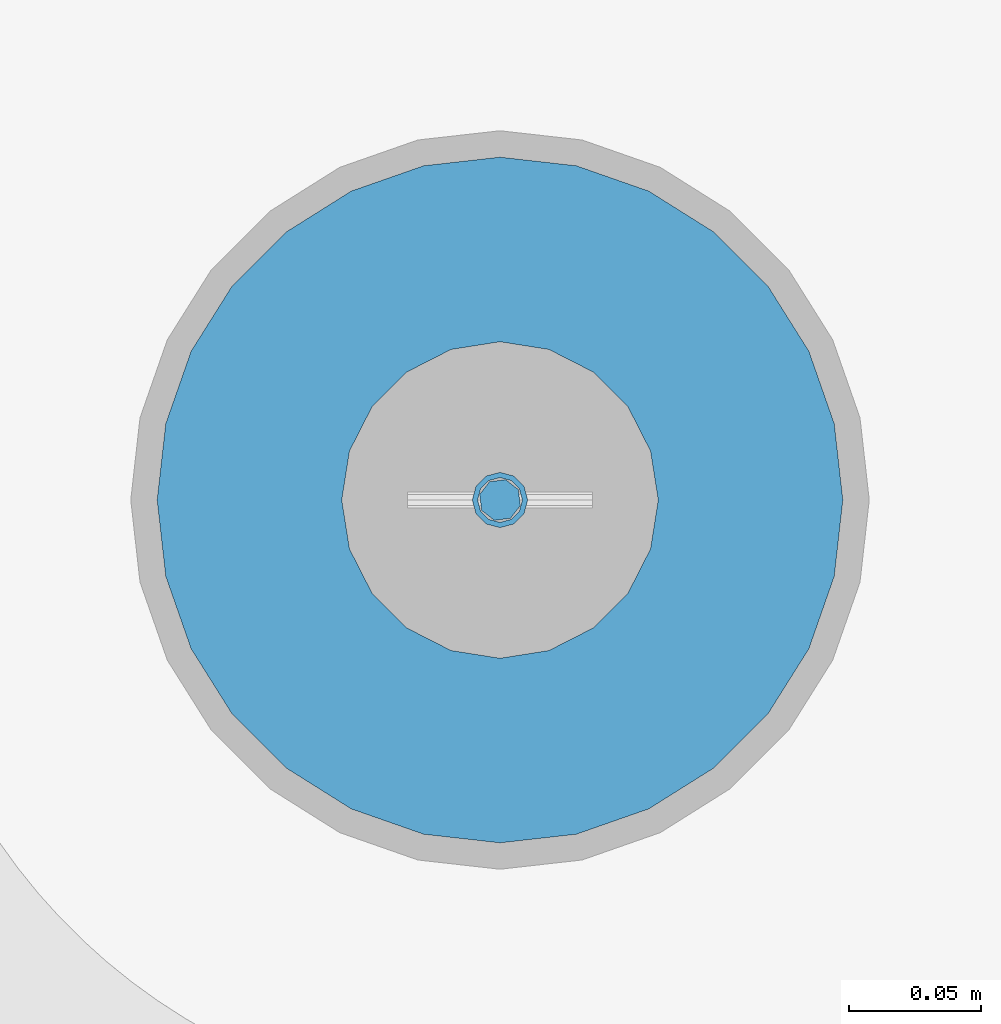
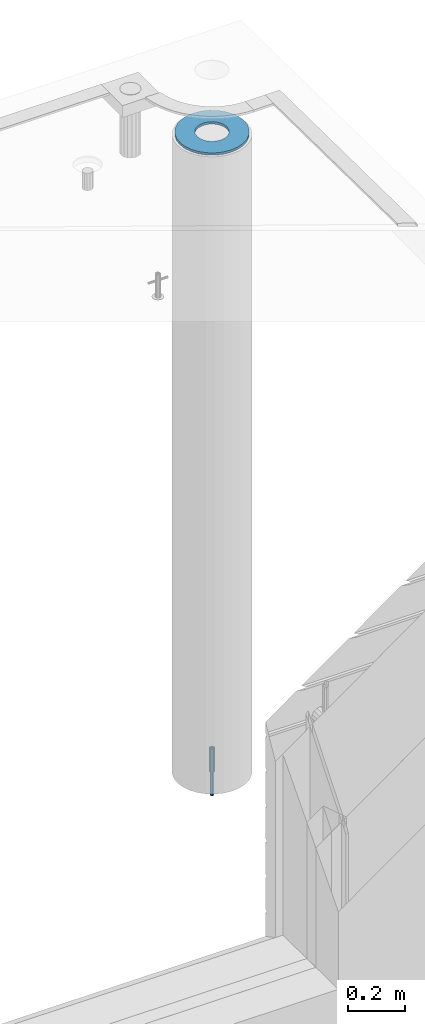
# One storey, part 33 of 325: 3 columns, 3 elements without a shape of their own.
"""IFC2X3 building model written with IfcOpenShell, lengths in millimetres."""

from ifc_helpers import new_model, si_unit, frame, origin_with_axes, place, context, subcontext, project, spatial, faceted_brep, material, type_object, element, aggregate, save


model = new_model("IFC2X3")

# Units and contexts
model_context = context("Model", 3, precision=1e-05, world=origin_with_axes())
body_context = subcontext(model_context, "Body", "Model", "MODEL_VIEW")
ifc_project = project(units=[si_unit("LENGTHUNIT", "METRE", prefix="MILLI"), si_unit("AREAUNIT", "SQUARE_METRE"), si_unit("VOLUMEUNIT", "CUBIC_METRE"), si_unit("MASSUNIT", "GRAM", prefix="KILO"), si_unit("TIMEUNIT", "SECOND"), si_unit("PLANEANGLEUNIT", "RADIAN"), si_unit("SOLIDANGLEUNIT", "STERADIAN"), si_unit("THERMODYNAMICTEMPERATUREUNIT", "DEGREE_CELSIUS"), si_unit("LUMINOUSINTENSITYUNIT", "LUMEN")], contexts=[model_context])

# Site, building, storey
site_placement = place(None, origin_with_axes())
site = spatial("IfcSite", under=ifc_project, at=site_placement, CompositionType="ELEMENT")
building_placement = place(site_placement, origin_with_axes())
building = spatial("IfcBuilding", under=site, at=building_placement, CompositionType="ELEMENT")
storey_placement = place(building_placement, origin_with_axes())
storey = spatial("IfcBuildingStorey", under=building, at=storey_placement, Name="1", CompositionType="ELEMENT", Elevation=0.0)

# Assemblies, columns
assembly_1_placement = place(storey_placement, origin_with_axes())
assembly_1 = element("IfcElementAssembly", 1, at=assembly_1_placement, inside=storey, AssemblyPlace="NOTDEFINED", PredefinedType="REINFORCEMENT_UNIT")
assembly_2_placement = place(assembly_1_placement, origin_with_axes())
assembly_2 = element("IfcElementAssembly", 2, at=assembly_2_placement, Name="Steel Assembly", AssemblyPlace="NOTDEFINED", PredefinedType="RIGID_FRAME")
ifc_material_1 = material(Name="STEEL/S235JR")
column_type_1 = type_object("IfcColumnType", Name="D16", PredefinedType="NOTDEFINED")
column_1_placement = place(assembly_2_placement, frame((35010.0004801435, 22669.9842012047, 81625.0), z_axis=(-0.261346946111888, -0.96524492941325, 0.0), x_axis=(0.0, 0.0, 1.0)))
column_1 = element("IfcColumn", 3, at=column_1_placement, type_object=column_type_1, material=ifc_material_1, Name="M16", ObjectType="D16", context=body_context, shape_type="Brep", body=[
    faceted_brep([(0.0, -8.0, 0.0), (0.0, -5.65685424949334, -5.65685424949334), (150.0, -5.65685424949697, -5.65685424949334), (150.0, -8.00000000000364, 0.0), (0.0, 0.0, -8.0), (150.0, -7.27595761418343e-12, -7.99999999999636), (0.0, 5.65685424949334, -5.65685424949334), (150.0, 5.6568542494897, -5.65685424949334), (0.0, 8.0, 0.0), (150.0, 8.0, -3.63797880709171e-12), (0.0, 5.65685424949334, 5.65685424949334), (150.0, 5.65685424949334, 5.65685424949697), (0.0, 0.0, 8.0), (150.0, -3.63797880709171e-12, 8.0), (0.0, -5.65685424949334, 5.65685424949334), (150.0, -5.65685424949334, 5.6568542494897)], [[[0, 1, 2, 3]], [[1, 4, 5, 2]], [[4, 6, 7, 5]], [[6, 8, 9, 7]], [[8, 10, 11, 9]], [[10, 12, 13, 11]], [[12, 14, 15, 13]], [[14, 0, 3, 15]], [[5, 7, 9, 11, 13, 15, 3, 2]], [[14, 12, 10, 8, 6, 4, 1, 0]]]),
])
aggregate(assembly_2, [column_1])
assembly_3_placement = place(assembly_1_placement, origin_with_axes())
assembly_3 = element("IfcElementAssembly", 4, at=assembly_3_placement, Name="Steel Assembly", AssemblyPlace="NOTDEFINED", PredefinedType="RIGID_FRAME")
ifc_material_2 = material(Name="STEEL/Steel_Undefined")
column_type_2 = type_object("IfcColumnType", PredefinedType="NOTDEFINED")
column_2_placement = place(assembly_3_placement, frame((35009.9987952044, 22669.984888838, 81725.0), z_axis=(0.0, 1.0, 0.0), x_axis=(0.0, 0.0, 1.0)))
column_2 = element("IfcColumn", 5, at=column_2_placement, type_object=column_type_2, material=ifc_material_2, context=body_context, shape_type="Brep", body=[
    faceted_brep([(0.0, -8.49999999999272, -1.45519152283669e-11), (0.0, -7.36121593215648, 4.24999999998545), (100.000000000262, -7.36121593215648, 4.24999999998545), (100.000000000262, -8.49999999999272, -1.45519152283669e-11), (0.0, -4.24999999998545, 7.36121593216376), (100.000000000262, -4.24999999998545, 7.36121593216376), (0.0, 1.45519152283669e-11, 8.49999999998545), (100.000000000262, 1.45519152283669e-11, 8.49999999998545), (0.0, 4.25000000001455, 7.36121593216376), (100.000000000262, 4.25000000001455, 7.36121593216376), (0.0, 7.36121593217104, 4.24999999998545), (100.000000000262, 7.36121593217104, 4.24999999998545), (0.0, 8.50000000000728, 0.0), (100.000000000262, 8.50000000000728, 0.0), (0.0, 7.36121593217104, -4.25000000001455), (100.000000000262, 7.36121593217104, -4.25000000001455), (0.0, 4.25000000000728, -7.36121593219286), (100.000000000262, 4.25000000000728, -7.36121593219286), (0.0, 7.27595761418343e-12, -8.5), (100.000000000262, 7.27595761418343e-12, -8.5), (0.0, -4.24999999999272, -7.36121593217831), (100.000000000262, -4.24999999999272, -7.36121593217831), (0.0, -7.36121593215648, -4.25), (100.000000000262, -7.36121593215648, -4.25), (0.0, -10.4999999999927, -1.45519152283669e-11), (0.0, -9.09326673972828, -5.25000000001455), (100.000000000262, -9.09326673972828, -5.25000000001455), (100.000000000262, -10.4999999999927, -1.45519152283669e-11), (0.0, -5.24999999998545, -9.09326673974283), (100.000000000262, -5.24999999998545, -9.09326673974283), (0.0, 7.27595761418343e-12, -10.5), (100.000000000262, 7.27595761418343e-12, -10.5), (0.0, 5.25000000001455, -9.09326673975738), (100.000000000262, 5.25000000001455, -9.09326673975738), (0.0, 9.09326673975011, -5.25000000001455), (100.000000000262, 9.09326673975011, -5.25000000001455), (0.0, 10.5000000000073, -1.45519152283669e-11), (100.000000000262, 10.5000000000073, -1.45519152283669e-11), (0.0, 9.09326673975011, 5.25), (100.000000000262, 9.09326673975011, 5.25), (0.0, 5.25000000000728, 9.09326673972828), (100.000000000262, 5.25000000000728, 9.09326673972828), (0.0, 1.45519152283669e-11, 10.4999999999854), (100.000000000262, 1.45519152283669e-11, 10.4999999999854), (0.0, -5.24999999999272, 9.09326673972828), (100.000000000262, -5.24999999999272, 9.09326673972828), (0.0, -9.09326673972828, 5.24999999998545), (100.000000000262, -9.09326673972828, 5.24999999998545)], [[[0, 1, 2, 3]], [[1, 4, 5, 2]], [[4, 6, 7, 5]], [[6, 8, 9, 7]], [[8, 10, 11, 9]], [[10, 12, 13, 11]], [[12, 14, 15, 13]], [[14, 16, 17, 15]], [[16, 18, 19, 17]], [[18, 20, 21, 19]], [[20, 22, 23, 21]], [[22, 0, 3, 23]], [[24, 25, 26, 27]], [[25, 28, 29, 26]], [[28, 30, 31, 29]], [[30, 32, 33, 31]], [[32, 34, 35, 33]], [[34, 36, 37, 35]], [[36, 38, 39, 37]], [[38, 40, 41, 39]], [[40, 42, 43, 41]], [[42, 44, 45, 43]], [[44, 46, 47, 45]], [[46, 24, 27, 47]], [[29, 31, 33, 35, 37, 39, 41, 43, 45, 47, 27, 26], [5, 7, 9, 11, 13, 15, 17, 19, 21, 23, 3, 2]], [[46, 44, 42, 40, 38, 36, 34, 32, 30, 28, 25, 24], [22, 20, 18, 16, 14, 12, 10, 8, 6, 4, 1, 0]]]),
])
aggregate(assembly_3, [column_2])
ifc_material_3 = material()
column_type_3 = type_object("IfcColumnType", Name="D260", PredefinedType="NOTDEFINED")
column_3_placement = place(assembly_1_placement, frame((35009.9987952044, 22669.984888838, 84435.0), z_axis=(-1.0, 3.00000001838171e-08, 0.0), x_axis=(0.0, 0.0, 1.0)))
column_3 = element("IfcColumn", 6, at=column_3_placement, type_object=column_type_3, material=ifc_material_3, Name="60", ObjectType="D260", context=body_context, shape_type="Brep", body=[
    faceted_brep([(10.0, -18.541019662498, -57.0633909777098), (0.0, -18.541019662498, -57.0633909777098), (0.0, -35.2671151375471, -48.5410196624944), (10.0, -35.2671151375471, -48.5410196624944), (0.0, -48.541019662498, -35.2671151375471), (10.0, -48.541019662498, -35.2671151375471), (0.0, -57.0633909777098, -18.5410196624944), (10.0, -57.0633909777098, -18.5410196624944), (0.0, -60.0, 0.0), (10.0, -60.0, 0.0), (0.0, -57.0633909777098, 18.5410196624944), (10.0, -57.0633909777098, 18.5410196624944), (0.0, -48.541019662498, 35.2671151375471), (10.0, -48.541019662498, 35.2671151375471), (0.0, -35.2671151375471, 48.5410196624944), (10.0, -35.2671151375471, 48.5410196624944), (0.0, -18.541019662498, 57.0633909777098), (10.0, -18.541019662498, 57.0633909777098), (0.0, 0.0, 60.0), (10.0, 0.0, 60.0), (0.0, 18.541019662498, 57.0633909777098), (10.0, 18.541019662498, 57.0633909777098), (0.0, 35.2671151375471, 48.5410196624944), (10.0, 35.2671151375471, 48.5410196624944), (0.0, 48.541019662498, 35.2671151375471), (10.0, 48.541019662498, 35.2671151375471), (0.0, 57.0633909777098, 18.5410196624944), (10.0, 57.0633909777098, 18.5410196624944), (0.0, 60.0, 0.0), (10.0, 60.0, 0.0), (0.0, 57.0633909777098, -18.5410196624944), (10.0, 57.0633909777098, -18.5410196624944), (0.0, 48.541019662498, -35.2671151375471), (10.0, 48.541019662498, -35.2671151375471), (0.0, 35.2671151375471, -48.5410196624944), (10.0, 35.2671151375471, -48.5410196624944), (0.0, 18.541019662498, -57.0633909777098), (10.0, 18.541019662498, -57.0633909777098), (0.0, 0.0, -60.0), (10.0, 0.0, -60.0), (0.0, -126.740628583637, -28.9277214143222), (0.0, -117.125952827315, -56.4048860852854), (10.0, -117.125952827315, -56.4048860852854), (10.0, -126.740628583637, -28.9277214143222), (0.0, -101.638092720845, -81.0536742416371), (10.0, -101.638092720845, -81.0536742416371), (0.0, -81.0536742416371, -101.638092720845), (10.0, -81.0536742416371, -101.638092720845), (0.0, -56.4048860852818, -117.125952827315), (10.0, -56.4048860852818, -117.125952827315), (0.0, -28.9277214143222, -126.740628583641), (10.0, -28.9277214143222, -126.740628583641), (0.0, 0.0, -130.0), (10.0, 0.0, -130.0), (0.0, 28.9277214143222, -126.740628583641), (10.0, 28.9277214143222, -126.740628583641), (0.0, 56.4048860852818, -117.125952827315), (10.0, 56.4048860852818, -117.125952827315), (0.0, 81.0536742416371, -101.638092720845), (10.0, 81.0536742416371, -101.638092720845), (0.0, 101.638092720845, -81.0536742416371), (10.0, 101.638092720845, -81.0536742416371), (0.0, 117.125952827315, -56.4048860852854), (10.0, 117.125952827315, -56.4048860852854), (0.0, 126.740628583637, -28.9277214143222), (10.0, 126.740628583637, -28.9277214143222), (0.0, 130.0, -1.81898940354586e-12), (10.0, 130.0, 0.0), (0.0, 126.740628583637, 28.9277214143222), (10.0, 126.740628583637, 28.9277214143222), (0.0, 117.125952827315, 56.4048860852854), (10.0, 117.125952827315, 56.4048860852854), (0.0, 101.638092720845, 81.0536742416371), (10.0, 101.638092720845, 81.0536742416371), (0.0, 81.0536742416371, 101.638092720845), (10.0, 81.0536742416371, 101.638092720845), (0.0, 56.4048860852818, 117.125952827315), (10.0, 56.4048860852818, 117.125952827315), (0.0, 28.9277214143222, 126.740628583641), (10.0, 28.9277214143222, 126.740628583641), (0.0, 0.0, 130.0), (10.0, 0.0, 130.0), (0.0, -28.9277214143222, 126.740628583641), (10.0, -28.9277214143222, 126.740628583641), (0.0, -56.4048860852818, 117.125952827315), (10.0, -56.4048860852818, 117.125952827315), (0.0, -81.0536742416371, 101.638092720845), (10.0, -81.0536742416371, 101.638092720845), (0.0, -101.638092720845, 81.0536742416371), (10.0, -101.638092720845, 81.0536742416371), (0.0, -117.125952827315, 56.4048860852854), (10.0, -117.125952827315, 56.4048860852854), (0.0, -126.740628583637, 28.9277214143222), (10.0, -126.740628583637, 28.9277214143222), (0.0, -130.0, -3.63797880709171e-12), (10.0, -130.0, 0.0)], [[[0, 1, 2, 3]], [[3, 2, 4, 5]], [[5, 4, 6, 7]], [[7, 6, 8, 9]], [[9, 8, 10, 11]], [[11, 10, 12, 13]], [[13, 12, 14, 15]], [[15, 14, 16, 17]], [[17, 16, 18, 19]], [[19, 18, 20, 21]], [[21, 20, 22, 23]], [[23, 22, 24, 25]], [[25, 24, 26, 27]], [[27, 26, 28, 29]], [[29, 28, 30, 31]], [[31, 30, 32, 33]], [[33, 32, 34, 35]], [[35, 34, 36, 37]], [[37, 36, 38, 39]], [[39, 38, 1, 0]], [[40, 41, 42, 43]], [[41, 44, 45, 42]], [[44, 46, 47, 45]], [[46, 48, 49, 47]], [[48, 50, 51, 49]], [[50, 52, 53, 51]], [[52, 54, 55, 53]], [[54, 56, 57, 55]], [[56, 58, 59, 57]], [[58, 60, 61, 59]], [[60, 62, 63, 61]], [[62, 64, 65, 63]], [[64, 66, 67, 65]], [[66, 68, 69, 67]], [[68, 70, 71, 69]], [[70, 72, 73, 71]], [[72, 74, 75, 73]], [[74, 76, 77, 75]], [[76, 78, 79, 77]], [[78, 80, 81, 79]], [[80, 82, 83, 81]], [[82, 84, 85, 83]], [[84, 86, 87, 85]], [[86, 88, 89, 87]], [[88, 90, 91, 89]], [[90, 92, 93, 91]], [[92, 94, 95, 93]], [[42, 45, 47, 49, 51, 53, 55, 57, 59, 61, 63, 65, 67, 69, 71, 73, 75, 77, 79, 81, 83, 85, 87, 89, 91, 93, 95, 43], [3, 5, 7, 9, 11, 13, 15, 17, 19, 21, 23, 25, 27, 29, 31, 33, 35, 37, 39, 0]], [[94, 40, 43, 95]], [[92, 90, 88, 86, 84, 82, 80, 78, 76, 74, 72, 70, 68, 66, 64, 62, 60, 58, 56, 54, 52, 50, 48, 46, 44, 41, 40, 94], [34, 32, 30, 28, 26, 24, 22, 20, 18, 16, 14, 12, 10, 8, 6, 4, 2, 1, 38, 36]]]),
])
aggregate(assembly_1, [assembly_3, assembly_2, column_3])

save(model, "model.ifc")
